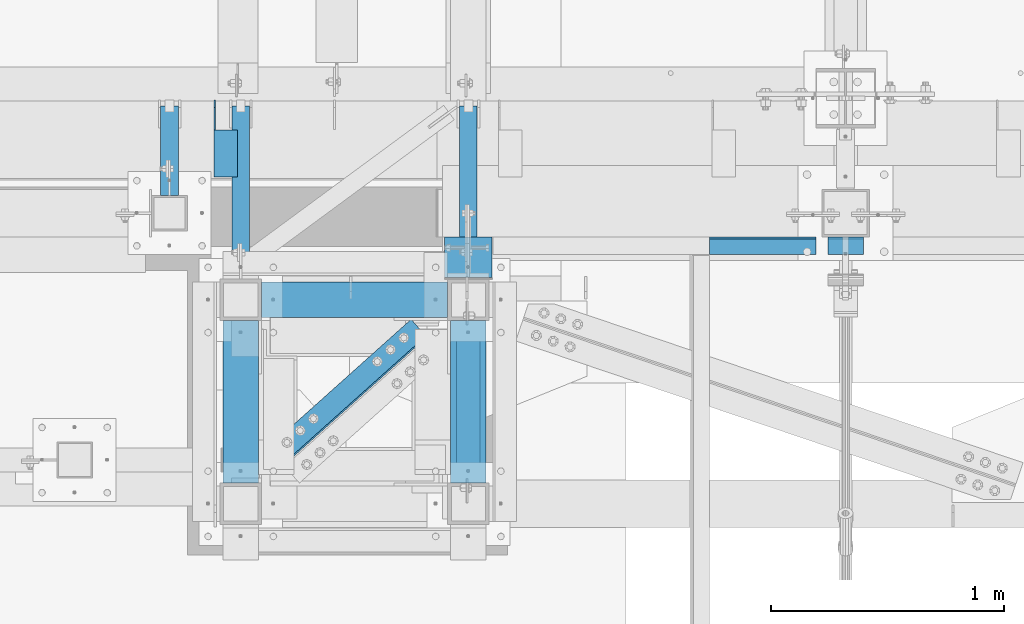
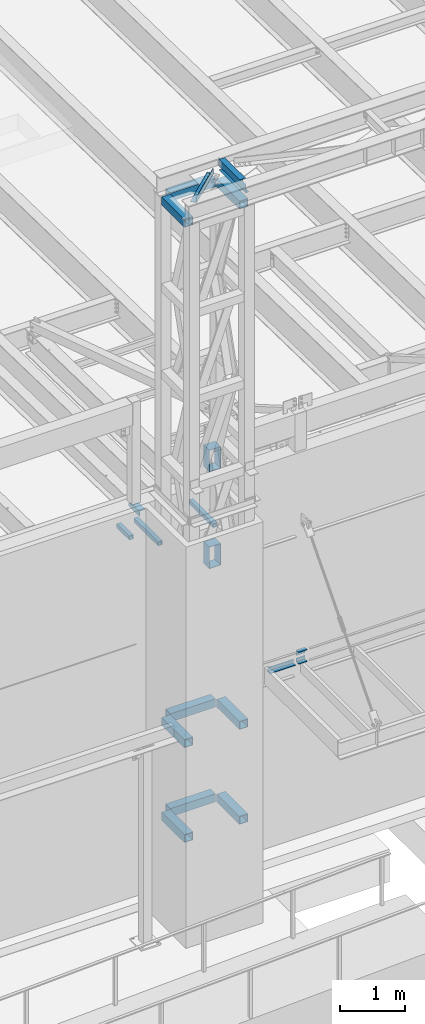
# One storey, part 1201 of 1763: 20 beams, 9 elements without a shape of their own.
"""IFC2X3 building model written with IfcOpenShell, lengths in millimetres."""

from ifc_helpers import new_model, si_unit, frame, origin_with_axes, place, context, subcontext, project, spatial, faceted_brep, material, type_object, element, aggregate, save


model = new_model("IFC2X3")

# Units and contexts
model_context = context("Model", 3, precision=1e-05, world=origin_with_axes())
body_context = subcontext(model_context, "Body", "Model", "MODEL_VIEW")
ifc_project = project(units=[si_unit("LENGTHUNIT", "METRE", prefix="MILLI"), si_unit("AREAUNIT", "SQUARE_METRE"), si_unit("VOLUMEUNIT", "CUBIC_METRE"), si_unit("MASSUNIT", "GRAM", prefix="KILO"), si_unit("TIMEUNIT", "SECOND"), si_unit("PLANEANGLEUNIT", "RADIAN"), si_unit("SOLIDANGLEUNIT", "STERADIAN"), si_unit("THERMODYNAMICTEMPERATUREUNIT", "DEGREE_CELSIUS"), si_unit("LUMINOUSINTENSITYUNIT", "LUMEN")], contexts=[model_context])

# Site, building, storey
site_placement = place(None, origin_with_axes())
site = spatial("IfcSite", under=ifc_project, at=site_placement, CompositionType="ELEMENT")
building_placement = place(site_placement, origin_with_axes())
building = spatial("IfcBuilding", under=site, at=building_placement, Name="Undefined", CompositionType="ELEMENT")
storey_placement = place(building_placement, origin_with_axes())
storey = spatial("IfcBuildingStorey", under=building, at=storey_placement, Name="Undefined", CompositionType="ELEMENT", Elevation=0.0)

# Assembly, beam
assembly_1_placement = place(storey_placement, origin_with_axes())
assembly_1 = element("IfcElementAssembly", 1, at=assembly_1_placement, inside=storey, Name="BEAM", AssemblyPlace="NOTDEFINED", PredefinedType="RIGID_FRAME")
ifc_material_1 = material(Name="STEEL/A36")
beam_type_1 = type_object("IfcBeamType", Name="L4X4X1/4", PredefinedType="NOTDEFINED")
beam_1_placement = place(assembly_1_placement, frame((-64249.6055562794, -13723.1435701431, 12153.9), z_axis=(0.0, 0.0, -1.0), x_axis=(0.0, -1.0, 0.0)))
beam_1 = element("IfcBeam", 2, at=beam_1_placement, type_object=beam_type_1, material=ifc_material_1, Name="BRACE", ObjectType="L4X4X1/4", context=body_context, shape_type="Brep", body=[
    faceted_brep([(127.793748474227, 44.4499999999971, -31.7500007627295), (127.793748474227, 50.8000000000029, -31.7500007627295), (127.793748474225, 50.8000000000029, -50.7999999999993), (127.793748474225, -50.8000000000029, -50.7999999999993), (127.793748474225, -50.8000000000029, -44.4500000000007), (127.793748474225, 44.4499999999971, -44.4500000000007), (31.7499999999673, 44.4499999999971, -31.7500001906901), (31.7499999999673, 50.8000000000029, -31.7500007627295), (-1.81898940354586e-10, 44.4500000000371, 50.7999999999374), (-1.96450855582952e-10, 50.8000000000393, 50.7999999999374), (0.0, 50.8000000000029, -1.90690116141923e-07), (0.0, 44.4499999999971, -1.90690116141923e-07), (329.406260681253, 44.4499999999971, 50.7999999999993), (329.406260681253, 50.8000000000029, 50.7999999999993), (329.406260681253, 44.4499999999971, -44.4500000000007), (329.406260681253, -50.8000000000029, -44.4500000000007), (329.406260681253, -50.8000000000029, -50.7999999999993), (329.406260681253, 50.8000000000029, -50.7999999999993)], [[[0, 1, 2, 3, 4, 5]], [[1, 0, 6, 7]], [[8, 9, 10, 11]], [[9, 8, 12, 13]], [[12, 14, 15, 16, 17, 13]], [[15, 14, 5, 4]], [[16, 15, 4, 3]], [[17, 16, 3, 2]], [[9, 13, 17, 2, 1, 7, 10]], [[6, 11, 10, 7]], [[0, 5, 14, 12, 8, 11, 6]]]),
])
aggregate(assembly_1, [beam_1])

assembly_2_placement = place(storey_placement, origin_with_axes())
assembly_2 = element("IfcElementAssembly", 3, at=assembly_2_placement, inside=storey, Name="ANGLE", AssemblyPlace="NOTDEFINED", PredefinedType="RIGID_FRAME")
beam_2_placement = place(assembly_2_placement, frame((-64219.1221853135, -15414.8880493635, 18672.175), z_axis=(-0.667212485940867, 0.744867436933988, 0.0), x_axis=(0.744867436933987, 0.667212485940868, 0.0)))
beam_2 = element("IfcBeam", 4, at=beam_2_placement, type_object=beam_type_1, material=ifc_material_1, Name="ANGLE", ObjectType="L4X4X1/4", context=body_context, shape_type="Brep", body=[
    faceted_brep([(246.665849237292, -50.7999999999993, -44.4499999995605), (246.665849237281, -50.7999999999993, -50.7999999995518), (1070.58066999025, -50.7999999999993, -50.7999999982494), (1070.58066999025, -50.7999999999993, -44.4499999982581), (246.665849237292, 44.4500000000007, -44.4499999995605), (1070.58066999025, 44.4500000000007, -44.4499999982581), (246.665849237394, 44.4500000000007, 50.8000000003231), (1070.58066999036, 44.4500000000007, 50.8000000016327), (246.665849237394, 50.7999999999993, 50.8000000003231), (1070.58066999036, 50.7999999999993, 50.8000000016327), (246.665849237281, 50.7999999999993, -50.7999999995518), (1070.58066999025, 50.7999999999993, -50.7999999982494)], [[[0, 1, 2, 3]], [[4, 0, 3, 5]], [[6, 4, 5, 7]], [[8, 6, 7, 9]], [[1, 0, 4, 6, 8, 10]], [[1, 10, 11, 2]], [[7, 5, 3, 2, 11, 9]], [[10, 8, 9, 11]]]),
])
aggregate(assembly_2, [beam_2])

assembly_3_placement = place(storey_placement, origin_with_axes())
assembly_3 = element("IfcElementAssembly", 5, at=assembly_3_placement, inside=storey, Name="BEAM", AssemblyPlace="NOTDEFINED", PredefinedType="RIGID_FRAME")
ifc_material_2 = material()
beam_type_2 = type_object("IfcBeamType", Name="HSS3X3X1/4", PredefinedType="NOTDEFINED")
beam_3_placement = place(assembly_3_placement, frame((-64490.482374092, -14131.9264769908, 11825.2875), z_axis=(0.0, 0.0, 1.0), x_axis=(0.0, 1.0, 0.0)))
beam_3 = element("IfcBeam", 6, at=beam_3_placement, type_object=beam_type_2, material=ifc_material_2, Name="BEAM", ObjectType="HSS3X3X1/4", context=body_context, shape_type="Brep", body=[
    faceted_brep([(0.0, 31.75, -31.75), (0.0, -31.75, -31.75), (383.382908373733, -31.75, -31.75), (383.382908373733, 31.75, -31.75), (0.0, -31.75, 31.75), (383.382908373733, -31.75, 31.75), (0.0, 31.75, 31.75), (383.382908373733, 31.75, 31.75), (0.0, 38.0999999999985, -38.1000000000004), (0.0, 38.0999999999985, 38.1000000000004), (383.382908373733, 38.0999999999985, 38.1000000000004), (383.382908373733, 38.0999999999985, -38.1000000000004), (0.0, -38.0999999999985, 38.1000000000004), (383.382908373733, -38.0999999999985, 38.1000000000004), (0.0, -38.0999999999985, -38.1000000000004), (383.382908373733, -38.0999999999985, -38.1000000000004)], [[[0, 1, 2, 3]], [[1, 4, 5, 2]], [[4, 6, 7, 5]], [[6, 0, 3, 7]], [[8, 9, 10, 11]], [[9, 12, 13, 10]], [[12, 14, 15, 13]], [[14, 8, 11, 15]], [[13, 15, 11, 10], [5, 7, 3, 2]], [[14, 12, 9, 8], [6, 4, 1, 0]]]),
])
aggregate(assembly_3, [beam_3])

assembly_4_placement = place(storey_placement, origin_with_axes())
assembly_4 = element("IfcElementAssembly", 7, at=assembly_4_placement, inside=storey, Name="BEAM", AssemblyPlace="NOTDEFINED", PredefinedType="RIGID_FRAME")
beam_4_placement = place(assembly_4_placement, frame((-63210.5025957005, -14490.7023151462, 11825.2875), z_axis=(0.0, 0.0, 1.0), x_axis=(0.0, 1.0, 0.0)))
beam_4 = element("IfcBeam", 8, at=beam_4_placement, type_object=beam_type_2, material=ifc_material_2, Name="BEAM", ObjectType="HSS3X3X1/4", context=body_context, shape_type="Brep", body=[
    faceted_brep([(0.0, 31.75, -31.75), (0.0, -31.75, -31.75), (742.15874652916, -31.75, -31.75), (742.15874652916, 31.75, -31.75), (0.0, -31.75, 31.75), (742.15874652916, -31.75, 31.75), (0.0, 31.75, 31.75), (742.15874652916, 31.75, 31.75), (0.0, 38.0999999999985, -38.1000000000004), (0.0, 38.0999999999985, 38.1000000000004), (742.15874652916, 38.0999999999985, 38.1000000000004), (742.15874652916, 38.0999999999985, -38.1000000000004), (0.0, -38.0999999999985, 38.1000000000004), (742.15874652916, -38.0999999999985, 38.1000000000004), (0.0, -38.0999999999985, -38.1000000000004), (742.15874652916, -38.0999999999985, -38.1000000000004)], [[[0, 1, 2, 3]], [[1, 4, 5, 2]], [[4, 6, 7, 5]], [[6, 0, 3, 7]], [[8, 9, 10, 11]], [[9, 12, 13, 10]], [[12, 14, 15, 13]], [[14, 8, 11, 15]], [[13, 15, 11, 10], [5, 7, 3, 2]], [[14, 12, 9, 8], [6, 4, 1, 0]]]),
])
aggregate(assembly_4, [beam_4])

assembly_5_placement = place(storey_placement, origin_with_axes())
assembly_5 = element("IfcElementAssembly", 9, at=assembly_5_placement, inside=storey, Name="BEAM", AssemblyPlace="NOTDEFINED", PredefinedType="RIGID_FRAME")
beam_5_placement = place(assembly_5_placement, frame((-64185.2277910131, -14490.7023151462, 11825.2875), z_axis=(0.0, 0.0, 1.0), x_axis=(0.0, 1.0, 0.0)))
beam_5 = element("IfcBeam", 10, at=beam_5_placement, type_object=beam_type_2, material=ifc_material_2, Name="BEAM", ObjectType="HSS3X3X1/4", context=body_context, shape_type="Brep", body=[
    faceted_brep([(0.0, 31.75, -31.75), (0.0, -31.75, -31.75), (742.15874652916, -31.75, -31.75), (742.15874652916, 31.75, -31.75), (0.0, -31.75, 31.75), (742.15874652916, -31.75, 31.75), (0.0, 31.75, 31.75), (742.15874652916, 31.75, 31.75), (0.0, 38.0999999999985, -38.1000000000004), (0.0, 38.0999999999985, 38.1000000000004), (742.15874652916, 38.0999999999985, 38.1000000000004), (742.15874652916, 38.0999999999985, -38.1000000000004), (0.0, -38.0999999999985, 38.1000000000004), (742.15874652916, -38.0999999999985, 38.1000000000004), (0.0, -38.0999999999985, -38.1000000000004), (742.15874652916, -38.0999999999985, -38.1000000000004)], [[[0, 1, 2, 3]], [[1, 4, 5, 2]], [[4, 6, 7, 5]], [[6, 0, 3, 7]], [[8, 9, 10, 11]], [[9, 12, 13, 10]], [[12, 14, 15, 13]], [[14, 8, 11, 15]], [[13, 15, 11, 10], [5, 7, 3, 2]], [[14, 12, 9, 8], [6, 4, 1, 0]]]),
])
aggregate(assembly_5, [beam_5])

# Assembly, beams
assembly_6_placement = place(storey_placement, origin_with_axes())
assembly_6 = element("IfcElementAssembly", 11, at=assembly_6_placement, inside=storey, Name="FRAME", AssemblyPlace="NOTDEFINED", PredefinedType="RIGID_FRAME")
beam_type_3 = type_object("IfcBeamType", Name="HSS6X6X3/8", PredefinedType="NOTDEFINED")
beam_6_placement = place(assembly_6_placement, frame((-64185.2275957006, -14579.6023151462, 18373.725), z_axis=(0.0, 0.0, 1.0), x_axis=(0.99999999999718, 2.37500000002911e-06, 0.0)))
beam_6 = element("IfcBeam", 12, at=beam_6_placement, type_object=beam_type_3, material=ifc_material_2, Name="BEAM", ObjectType="HSS6X6X3/8", context=body_context, shape_type="Brep", body=[
    faceted_brep([(88.8999999999996, 66.6750000000029, -66.6749999999993), (88.8996463353687, -66.6749999999556, -66.6749999999993), (885.824841654605, -66.6750000000393, -66.6749999999993), (885.825158360378, 66.6749999998519, -66.6749999999993), (88.8996463353687, -66.6749999999556, 66.6749999999993), (885.824841654605, -66.6750000000393, 66.6749999999993), (88.8999999999996, 66.6750000000029, 66.6749999999993), (885.825158360378, 66.6749999998519, 66.6749999999993), (88.8999999999996, 76.1999999999971, -76.2000000000007), (88.8999999999996, 76.1999999999971, 76.2000000000007), (885.825180982218, 76.1999999998425, 76.2000000000007), (885.825180982218, 76.1999999998425, -76.2000000000007), (88.8996237135289, -76.1999999999498, 76.2000000000007), (885.824819032772, -76.2000000000335, 76.2000000000007), (88.8996237135289, -76.1999999999498, -76.2000000000007), (885.824819032772, -76.2000000000335, -76.2000000000007)], [[[0, 1, 2, 3]], [[1, 4, 5, 2]], [[4, 6, 7, 5]], [[6, 0, 3, 7]], [[8, 9, 10, 11]], [[9, 12, 13, 10]], [[12, 14, 15, 13]], [[14, 8, 11, 15]], [[13, 15, 11, 10], [5, 7, 3, 2]], [[14, 12, 9, 8], [6, 4, 1, 0]]]),
])
beam_7_placement = place(assembly_6_placement, frame((-63210.5025951483, -15452.7272159449, 18373.725), z_axis=(0.0, 0.0, 1.0), x_axis=(0.0, 1.0, 0.0)))
beam_7 = element("IfcBeam", 13, at=beam_7_placement, type_object=beam_type_3, material=ifc_material_2, Name="BEAM", ObjectType="HSS6X6X3/8", context=body_context, shape_type="Brep", body=[
    faceted_brep([(88.8999008650717, 66.6749999997191, -66.6749999999993), (88.8999007322054, -66.6750000002794, -66.6749999999993), (784.224900732206, -66.6750000025058, -66.6749999999993), (784.224900865072, 66.6749999974927, -66.6749999999993), (88.8999007322054, -66.6750000002794, 66.6749999999993), (784.224900732206, -66.6750000025058, 66.6749999999993), (88.8999008650717, 66.6749999997191, 66.6749999999993), (784.224900865072, 66.6749999974927, 66.6749999999993), (88.8999008745614, 76.1999999997206, -76.2000000000007), (88.8999008745614, 76.1999999997206, 76.2000000000007), (784.224900874562, 76.1999999974942, 76.2000000000007), (784.224900874562, 76.1999999974942, -76.2000000000007), (88.8999007227158, -76.2000000002809, 76.2000000000007), (784.224900722716, -76.2000000025073, 76.2000000000007), (88.8999007227158, -76.2000000002809, -76.2000000000007), (784.224900722716, -76.2000000025073, -76.2000000000007)], [[[0, 1, 2, 3]], [[1, 4, 5, 2]], [[4, 6, 7, 5]], [[6, 0, 3, 7]], [[8, 9, 10, 11]], [[9, 12, 13, 10]], [[12, 14, 15, 13]], [[14, 8, 11, 15]], [[13, 15, 11, 10], [5, 7, 3, 2]], [[14, 12, 9, 8], [6, 4, 1, 0]]]),
])
beam_8_placement = place(assembly_6_placement, frame((-64185.2275951483, -15452.7272100983, 18373.725), z_axis=(0.0, 0.0, 1.0), x_axis=(0.0, 1.0, 0.0)))
beam_8 = element("IfcBeam", 14, at=beam_8_placement, type_object=beam_type_3, material=ifc_material_2, Name="BEAM", ObjectType="HSS6X6X3/8", context=body_context, shape_type="Brep", body=[
    faceted_brep([(88.8999008650717, 66.6749999997191, -66.6749999999993), (88.8999007322054, -66.6750000002794, -66.6749999999993), (784.224900732206, -66.6750000025058, -66.6749999999993), (784.224900865072, 66.6749999974927, -66.6749999999993), (88.8999007322054, -66.6750000002794, 66.6749999999993), (784.224900732206, -66.6750000025058, 66.6749999999993), (88.8999008650717, 66.6749999997191, 66.6749999999993), (784.224900865072, 66.6749999974927, 66.6749999999993), (88.8999008745614, 76.1999999997206, -76.2000000000007), (88.8999008745614, 76.1999999997206, 76.2000000000007), (784.224900874562, 76.1999999974942, 76.2000000000007), (784.224900874562, 76.1999999974942, -76.2000000000007), (88.8999007227158, -76.2000000002809, 76.2000000000007), (784.224900722716, -76.2000000025073, 76.2000000000007), (88.8999007227158, -76.2000000002809, -76.2000000000007), (784.224900722716, -76.2000000025073, -76.2000000000007)], [[[0, 1, 2, 3]], [[1, 4, 5, 2]], [[4, 6, 7, 5]], [[6, 0, 3, 7]], [[8, 9, 10, 11]], [[9, 12, 13, 10]], [[12, 14, 15, 13]], [[14, 8, 11, 15]], [[13, 15, 11, 10], [5, 7, 3, 2]], [[14, 12, 9, 8], [6, 4, 1, 0]]]),
])
beam_9_placement = place(assembly_6_placement, frame((-64185.2275957006, -14579.6023151462, 8623.3), z_axis=(0.0, 0.0, 1.0), x_axis=(0.99999999999718, 2.37500000002911e-06, 0.0)))
beam_9 = element("IfcBeam", 15, at=beam_9_placement, type_object=beam_type_3, material=ifc_material_2, Name="BEAM", ObjectType="HSS6X6X3/8", context=body_context, shape_type="Brep", body=[
    faceted_brep([(88.8999999999996, 66.6750000000029, -66.6749999999993), (88.8996463353687, -66.6749999999556, -66.6749999999993), (885.824841654605, -66.6750000000393, -66.6749999999993), (885.825158360378, 66.6749999998519, -66.6749999999993), (88.8996463353687, -66.6749999999556, 66.6749999999993), (885.824841654605, -66.6750000000393, 66.6749999999993), (88.8999999999996, 66.6750000000029, 66.6749999999993), (885.825158360378, 66.6749999998519, 66.6749999999993), (88.8999999999996, 76.1999999999971, -76.2000000000007), (88.8999999999996, 76.1999999999971, 76.2000000000007), (885.825180982218, 76.1999999998425, 76.2000000000007), (885.825180982218, 76.1999999998425, -76.2000000000007), (88.8996237135289, -76.1999999999498, 76.2000000000007), (885.824819032772, -76.2000000000335, 76.2000000000007), (88.8996237135289, -76.1999999999498, -76.2000000000007), (885.824819032772, -76.2000000000335, -76.2000000000007)], [[[0, 1, 2, 3]], [[1, 4, 5, 2]], [[4, 6, 7, 5]], [[6, 0, 3, 7]], [[8, 9, 10, 11]], [[9, 12, 13, 10]], [[12, 14, 15, 13]], [[14, 8, 11, 15]], [[13, 15, 11, 10], [5, 7, 3, 2]], [[14, 12, 9, 8], [6, 4, 1, 0]]]),
])
beam_10_placement = place(assembly_6_placement, frame((-63210.5025957005, -15452.7273151462, 8623.3), z_axis=(0.0, 0.0, 1.0), x_axis=(0.0, 1.0, 0.0)))
beam_10 = element("IfcBeam", 16, at=beam_10_placement, type_object=beam_type_3, material=ifc_material_2, Name="BEAM", ObjectType="HSS6X6X3/8", context=body_context, shape_type="Brep", body=[
    faceted_brep([(88.8999999999996, 66.6750000000029, -66.6749999999993), (88.8999999999996, -66.6750000000029, -66.6749999999993), (784.225, -66.6750000000029, -66.6749999999993), (784.225, 66.6750000000029, -66.6749999999993), (88.8999999999996, -66.6750000000029, 66.6749999999993), (784.225, -66.6750000000029, 66.6749999999993), (88.8999999999996, 66.6750000000029, 66.6749999999993), (784.225, 66.6750000000029, 66.6749999999993), (88.8999999999996, 76.1999999999971, -76.2000000000007), (88.8999999999996, 76.1999999999971, 76.2000000000007), (784.225, 76.1999999999971, 76.2000000000007), (784.225, 76.1999999999971, -76.2000000000007), (88.8999999999996, -76.1999999999971, 76.2000000000007), (784.225, -76.1999999999971, 76.2000000000007), (88.8999999999996, -76.1999999999971, -76.2000000000007), (784.225, -76.1999999999971, -76.2000000000007)], [[[0, 1, 2, 3]], [[1, 4, 5, 2]], [[4, 6, 7, 5]], [[6, 0, 3, 7]], [[8, 9, 10, 11]], [[9, 12, 13, 10]], [[12, 14, 15, 13]], [[14, 8, 11, 15]], [[13, 15, 11, 10], [5, 7, 3, 2]], [[14, 12, 9, 8], [6, 4, 1, 0]]]),
])
beam_11_placement = place(assembly_6_placement, frame((-64185.2275957006, -15452.7273151462, 8623.3), z_axis=(0.0, 0.0, 1.0), x_axis=(0.0, 1.0, 0.0)))
beam_11 = element("IfcBeam", 17, at=beam_11_placement, type_object=beam_type_3, material=ifc_material_2, Name="BEAM", ObjectType="HSS6X6X3/8", context=body_context, shape_type="Brep", body=[
    faceted_brep([(88.8999999999996, 66.6750000000029, -66.6749999999993), (88.8999999999996, -66.6750000000029, -66.6749999999993), (784.225, -66.6750000000029, -66.6749999999993), (784.225, 66.6750000000029, -66.6749999999993), (88.8999999999996, -66.6750000000029, 66.6749999999993), (784.225, -66.6750000000029, 66.6749999999993), (88.8999999999996, 66.6750000000029, 66.6749999999993), (784.225, 66.6750000000029, 66.6749999999993), (88.8999999999996, 76.1999999999971, -76.2000000000007), (88.8999999999996, 76.1999999999971, 76.2000000000007), (784.225, 76.1999999999971, 76.2000000000007), (784.225, 76.1999999999971, -76.2000000000007), (88.8999999999996, -76.1999999999971, 76.2000000000007), (784.225, -76.1999999999971, 76.2000000000007), (88.8999999999996, -76.1999999999971, -76.2000000000007), (784.225, -76.1999999999971, -76.2000000000007)], [[[0, 1, 2, 3]], [[1, 4, 5, 2]], [[4, 6, 7, 5]], [[6, 0, 3, 7]], [[8, 9, 10, 11]], [[9, 12, 13, 10]], [[12, 14, 15, 13]], [[14, 8, 11, 15]], [[13, 15, 11, 10], [5, 7, 3, 2]], [[14, 12, 9, 8], [6, 4, 1, 0]]]),
])
beam_12_placement = place(assembly_6_placement, frame((-64185.2275957006, -14579.6023151462, 6845.3), z_axis=(0.0, 0.0, 1.0), x_axis=(0.99999999999718, 2.37500000002911e-06, 0.0)))
beam_12 = element("IfcBeam", 18, at=beam_12_placement, type_object=beam_type_3, material=ifc_material_2, Name="BEAM", ObjectType="HSS6X6X3/8", context=body_context, shape_type="Brep", body=[
    faceted_brep([(88.8999999999996, 66.6750000000029, -66.6749999999993), (88.8996463353687, -66.6749999999556, -66.6749999999993), (885.824841654605, -66.6750000000393, -66.6749999999993), (885.825158360378, 66.6749999998519, -66.6749999999993), (88.8996463353687, -66.6749999999556, 66.6749999999993), (885.824841654605, -66.6750000000393, 66.6749999999993), (88.8999999999996, 66.6750000000029, 66.6749999999993), (885.825158360378, 66.6749999998519, 66.6749999999993), (88.8999999999996, 76.1999999999971, -76.2000000000007), (88.8999999999996, 76.1999999999971, 76.2000000000007), (885.825180982218, 76.1999999998425, 76.2000000000007), (885.825180982218, 76.1999999998425, -76.2000000000007), (88.8996237135289, -76.1999999999498, 76.2000000000007), (885.824819032772, -76.2000000000335, 76.2000000000007), (88.8996237135289, -76.1999999999498, -76.2000000000007), (885.824819032772, -76.2000000000335, -76.2000000000007)], [[[0, 1, 2, 3]], [[1, 4, 5, 2]], [[4, 6, 7, 5]], [[6, 0, 3, 7]], [[8, 9, 10, 11]], [[9, 12, 13, 10]], [[12, 14, 15, 13]], [[14, 8, 11, 15]], [[13, 15, 11, 10], [5, 7, 3, 2]], [[14, 12, 9, 8], [6, 4, 1, 0]]]),
])
beam_13_placement = place(assembly_6_placement, frame((-63210.5025957005, -15452.7273151462, 6845.3), z_axis=(0.0, 0.0, 1.0), x_axis=(0.0, 1.0, 0.0)))
beam_13 = element("IfcBeam", 19, at=beam_13_placement, type_object=beam_type_3, material=ifc_material_2, Name="BEAM", ObjectType="HSS6X6X3/8", context=body_context, shape_type="Brep", body=[
    faceted_brep([(88.8999999999996, 66.6750000000029, -66.6749999999993), (88.8999999999996, -66.6750000000029, -66.6749999999993), (784.225, -66.6750000000029, -66.6749999999993), (784.225, 66.6750000000029, -66.6749999999993), (88.8999999999996, -66.6750000000029, 66.6749999999993), (784.225, -66.6750000000029, 66.6749999999993), (88.8999999999996, 66.6750000000029, 66.6749999999993), (784.225, 66.6750000000029, 66.6749999999993), (88.8999999999996, 76.1999999999971, -76.2000000000007), (88.8999999999996, 76.1999999999971, 76.2000000000007), (784.225, 76.1999999999971, 76.2000000000007), (784.225, 76.1999999999971, -76.2000000000007), (88.8999999999996, -76.1999999999971, 76.2000000000007), (784.225, -76.1999999999971, 76.2000000000007), (88.8999999999996, -76.1999999999971, -76.2000000000007), (784.225, -76.1999999999971, -76.2000000000007)], [[[0, 1, 2, 3]], [[1, 4, 5, 2]], [[4, 6, 7, 5]], [[6, 0, 3, 7]], [[8, 9, 10, 11]], [[9, 12, 13, 10]], [[12, 14, 15, 13]], [[14, 8, 11, 15]], [[13, 15, 11, 10], [5, 7, 3, 2]], [[14, 12, 9, 8], [6, 4, 1, 0]]]),
])
beam_14_placement = place(assembly_6_placement, frame((-64185.2275957006, -15452.7273151462, 6845.3), z_axis=(0.0, 0.0, 1.0), x_axis=(0.0, 1.0, 0.0)))
beam_14 = element("IfcBeam", 20, at=beam_14_placement, type_object=beam_type_3, material=ifc_material_2, Name="BEAM", ObjectType="HSS6X6X3/8", context=body_context, shape_type="Brep", body=[
    faceted_brep([(88.8999999999996, 66.6750000000029, -66.6749999999993), (88.8999999999996, -66.6750000000029, -66.6749999999993), (784.225, -66.6750000000029, -66.6749999999993), (784.225, 66.6750000000029, -66.6749999999993), (88.8999999999996, -66.6750000000029, 66.6749999999993), (784.225, -66.6750000000029, 66.6749999999993), (88.8999999999996, 66.6750000000029, 66.6749999999993), (784.225, 66.6750000000029, 66.6749999999993), (88.8999999999996, 76.1999999999971, -76.2000000000007), (88.8999999999996, 76.1999999999971, 76.2000000000007), (784.225, 76.1999999999971, 76.2000000000007), (784.225, 76.1999999999971, -76.2000000000007), (88.8999999999996, -76.1999999999971, 76.2000000000007), (784.225, -76.1999999999971, 76.2000000000007), (88.8999999999996, -76.1999999999971, -76.2000000000007), (784.225, -76.1999999999971, -76.2000000000007)], [[[0, 1, 2, 3]], [[1, 4, 5, 2]], [[4, 6, 7, 5]], [[6, 0, 3, 7]], [[8, 9, 10, 11]], [[9, 12, 13, 10]], [[12, 14, 15, 13]], [[14, 8, 11, 15]], [[13, 15, 11, 10], [5, 7, 3, 2]], [[14, 12, 9, 8], [6, 4, 1, 0]]]),
])
beam_type_4 = type_object("IfcBeamType", Name="HSS16X8X1/4", PredefinedType="NOTDEFINED")
beam_15_placement = place(assembly_6_placement, frame((-63210.5025999486, -14490.702315147, 13055.6221257957), z_axis=(0.0, 0.0, 1.0), x_axis=(0.0, 1.0, 0.0)))
beam_15 = element("IfcBeam", 21, at=beam_15_placement, type_object=beam_type_4, material=ifc_material_2, Name="BEAM", ObjectType="HSS16X8X1/4", context=body_context, shape_type="Brep", body=[
    faceted_brep([(6.35000009548457, 95.2499999999854, -196.85), (6.3499999048563, -95.2500000000146, -196.85), (180.974693656795, -95.2500000003201, -196.85), (180.97469365679, 95.2499999996799, -196.85), (6.3499999048563, -95.2500000000146, 196.85), (180.974693656795, -95.2500000003201, 196.85), (6.35000009548457, 95.2499999999854, 196.85), (180.97469365679, 95.2499999996799, 196.85), (6.35000010184012, 101.599999999984, -203.200000000001), (6.35000010184012, 101.599999999984, 203.200000000001), (180.974693656788, 101.599999999678, 203.200000000001), (180.974693656788, 101.599999999678, -203.200000000001), (6.34999989850257, -101.600000000013, 203.200000000001), (180.974693656795, -101.600000000326, 203.200000000001), (6.34999989850257, -101.600000000013, -203.200000000001), (180.974693656795, -101.600000000326, -203.200000000001)], [[[0, 1, 2, 3]], [[1, 4, 5, 2]], [[4, 6, 7, 5]], [[6, 0, 3, 7]], [[8, 9, 10, 11]], [[9, 12, 13, 10]], [[12, 14, 15, 13]], [[14, 8, 11, 15]], [[13, 15, 11, 10], [5, 7, 3, 2]], [[14, 12, 9, 8], [6, 4, 1, 0]]]),
])
beam_16_placement = place(assembly_6_placement, frame((-63210.5025957006, -14490.7023090427, 11239.5), z_axis=(0.0, 0.0, 1.0), x_axis=(0.0, 1.0, 0.0)))
beam_16 = element("IfcBeam", 22, at=beam_16_placement, type_object=beam_type_4, material=ifc_material_2, Name="BEAM", ObjectType="HSS16X8X1/4", context=body_context, shape_type="Brep", body=[
    faceted_brep([(6.35000009548457, 95.2499999999854, -196.85), (6.3499999048563, -95.2500000000146, -196.85), (180.974693656795, -95.2500000003201, -196.85), (180.97469365679, 95.2499999996799, -196.85), (6.3499999048563, -95.2500000000146, 196.85), (180.974693656795, -95.2500000003201, 196.85), (6.35000009548457, 95.2499999999854, 196.85), (180.97469365679, 95.2499999996799, 196.85), (6.35000010184012, 101.599999999984, -203.200000000001), (6.35000010184012, 101.599999999984, 203.200000000001), (180.974693656788, 101.599999999678, 203.200000000001), (180.974693656788, 101.599999999678, -203.200000000001), (6.34999989850257, -101.600000000013, 203.200000000001), (180.974693656795, -101.600000000326, 203.200000000001), (6.34999989850257, -101.600000000013, -203.200000000001), (180.974693656795, -101.600000000326, -203.200000000001)], [[[0, 1, 2, 3]], [[1, 4, 5, 2]], [[4, 6, 7, 5]], [[6, 0, 3, 7]], [[8, 9, 10, 11]], [[9, 12, 13, 10]], [[12, 14, 15, 13]], [[14, 8, 11, 15]], [[13, 15, 11, 10], [5, 7, 3, 2]], [[14, 12, 9, 8], [6, 4, 1, 0]]]),
])
aggregate(assembly_6, [beam_6, beam_7, beam_8, beam_9, beam_10, beam_11, beam_12, beam_13, beam_14, beam_15, beam_16])

# Assembly, beam
assembly_7_placement = place(storey_placement, origin_with_axes())
assembly_7 = element("IfcElementAssembly", 23, at=assembly_7_placement, inside=storey, Name="BEAM", AssemblyPlace="NOTDEFINED", PredefinedType="RIGID_FRAME")
ifc_material_3 = material(Name="STEEL/A992")
beam_type_5 = type_object("IfcBeamType", Name="W8X10", PredefinedType="NOTDEFINED")
beam_17_placement = place(assembly_7_placement, frame((-63210.5025957005, -15452.7272158686, 18721.3875), z_axis=(0.0, 0.0, 1.0), x_axis=(0.0, 1.0, 0.0)))
beam_17 = element("IfcBeam", 24, at=beam_17_placement, type_object=beam_type_5, material=ifc_material_3, Name="BEAM", ObjectType="W8X10", context=body_context, shape_type="Brep", body=[
    faceted_brep([(754.062393478449, 2.68138280149287, -95.25), (754.062393478942, 2.68111437270272, -100.012500000001), (754.062304651585, 50.8000000000029, -100.012500000001), (754.062304651585, 50.8000000000029, -95.25), (855.662499936947, 2.68157035501645, -95.25), (855.662499936945, 2.68130192623357, -100.012500000001), (119.062499920861, 2.38124999999854, 95.25), (119.062548753725, 50.7999999995227, 95.25), (754.062499920858, 50.8000000000029, 95.25), (754.062499920858, 2.38124999999854, 95.25), (119.062499920861, -50.8000000000029, 100.012500000001), (119.062548753725, 50.7999999995227, 100.012500000001), (119.062499920861, 2.38124999999854, 74.3525014877341), (119.062499920861, -2.38124999999854, 74.3525014877341), (119.062499920861, -2.38124999999854, 95.25), (119.062499920861, -50.8000000000029, 95.25), (118.095769998274, 2.38124999999854, 69.4924219696877), (118.095769998274, -2.38124999999854, 69.4924219696877), (115.342756097796, 2.38124999999854, 65.3722455015341), (115.342756097796, -2.38124999999854, 65.3722455015341), (111.222579629642, 2.38124999999854, 62.6192316010565), (111.222579629642, -2.38124999999854, 62.6192316010565), (106.362500111596, 2.38124999999854, 61.652501678469), (106.362500111596, -2.38124999999854, 61.652501678469), (17.462499935149, 2.38124999999854, 61.652501678469), (17.4624999065727, -2.38124999999854, 61.652501678469), (119.062558086149, 50.7999999995154, -95.25), (119.062558086149, 50.7999999995154, -100.012500000001), (119.062597975411, 2.68138261623972, -100.012500000001), (119.062597975906, 2.68111418744229, -95.25), (17.462499936948, 2.68119506251242, -100.012500000001), (17.4624999369462, 2.68092663372954, -95.25), (17.4624996160601, -50.8000000000029, -100.012500000001), (17.4624996160601, -50.8000000000029, -95.25), (17.4624999065727, -2.38124999999854, -95.25), (17.462499935149, 2.38124999999854, -95.25), (855.662499616057, -50.8000000000029, -100.012500000001), (855.662499616057, -50.8000000000029, -95.25), (855.66249990657, -2.38124999999854, -95.25), (761.902420212076, -2.38124999999854, 62.6192316010565), (757.782243743923, -2.38124999999854, 65.3722455015341), (755.029229843445, -2.38124999999854, 69.4924219696877), (754.062499920858, -2.38124999999854, 74.3525014877341), (754.062499920858, -2.38124999999854, 95.25), (855.66249990657, -2.38124999999854, 61.652501678469), (766.762499730123, -2.38124999999854, 61.652501678469), (754.062499920858, -50.8000000000029, 95.25), (754.062499920858, -50.8000000000029, 100.012500000001), (754.062499920858, 50.8000000000029, 100.012500000001), (754.062499920858, 2.38124999999854, 74.3525014877341), (755.029229843445, 2.38124999999854, 69.4924219696877), (757.782243743923, 2.38124999999854, 65.3722455015341), (761.902420212076, 2.38124999999854, 62.6192316010565), (766.762499730123, 2.38124999999854, 61.652501678469), (855.662499935146, 2.38124999999854, 61.652501678469), (855.662499935146, 2.38124999999854, -95.25)], [[[0, 1, 2, 3]], [[4, 5, 1, 0]], [[6, 7, 8, 9]], [[10, 11, 7, 6, 12, 13, 14, 15]], [[13, 12, 16, 17]], [[17, 16, 18, 19]], [[19, 18, 20, 21]], [[21, 20, 22, 23]], [[23, 22, 24, 25]], [[26, 27, 28, 29]], [[29, 28, 30, 31]], [[32, 33, 34, 25, 24, 35, 31, 30]], [[33, 32, 36, 37]], [[34, 33, 37, 38]], [[39, 40, 41, 42, 43, 14, 13, 17, 19, 21, 23, 25, 34, 38, 44, 45]], [[15, 14, 43, 46]], [[10, 15, 46, 47]], [[11, 10, 47, 48]], [[7, 11, 48, 8]], [[47, 46, 43, 42, 49, 9, 8, 48]], [[41, 50, 49, 42]], [[40, 51, 50, 41]], [[39, 52, 51, 40]], [[45, 53, 52, 39]], [[44, 54, 53, 45]], [[55, 35, 24, 22, 20, 18, 16, 12, 6, 9, 49, 50, 51, 52, 53, 54]], [[3, 26, 29, 31, 35, 55, 4, 0]], [[27, 26, 3, 2]], [[36, 32, 30, 28, 27, 2, 1, 5]], [[55, 54, 44, 38, 37, 36, 5, 4]]]),
])
aggregate(assembly_7, [beam_17])

assembly_8_placement = place(storey_placement, origin_with_axes())
assembly_8 = element("IfcElementAssembly", 25, at=assembly_8_placement, inside=storey, Name="COLUMN", AssemblyPlace="NOTDEFINED", PredefinedType="RIGID_FRAME")
beam_type_6 = type_object("IfcBeamType", Name="L3X3X3/8", PredefinedType="NOTDEFINED")
beam_18_placement = place(assembly_8_placement, frame((-61518.2270160026, -14347.8276478541, 8648.70000000001), z_axis=(0.0, -1.0, 0.0), x_axis=(-1.0, 0.0, 0.0)))
beam_18 = element("IfcBeam", 26, at=beam_18_placement, type_object=beam_type_6, material=ifc_material_1, Name="ANGLE", ObjectType="L3X3X3/8", context=body_context, shape_type="Brep", body=[
    faceted_brep([(0.0, 38.0999999999985, -38.1000000000004), (0.0, 38.0999999999985, 38.1000000000004), (152.400006103515, 38.0999999999985, 38.1000000000058), (152.400006103515, 38.0999999999985, -38.1000000000058), (1.45519152283669e-11, 28.5750000000007, 38.1000000000022), (152.400000000023, 28.5750000000007, 38.0999999999622), (0.0, 28.5750000000007, -28.5750000000007), (152.400000000009, 28.5750000000007, -28.5750000000389), (0.0, -38.1000000000004, -28.5750000000007), (152.400000000009, -38.1000000000004, -28.5750000000389), (0.0, -38.0999999999985, -38.1000000000004), (152.400006103515, -38.0999999999985, -38.1000000000058)], [[[0, 1, 2, 3]], [[1, 4, 5, 2]], [[4, 6, 7, 5]], [[6, 8, 9, 7]], [[8, 10, 11, 9]], [[10, 0, 3, 11]], [[5, 7, 9, 11, 3, 2]], [[10, 8, 6, 4, 1, 0]]]),
])

assembly_9_placement = place(storey_placement, origin_with_axes())
assembly_9 = element("IfcElementAssembly", 27, at=assembly_9_placement, inside=storey, Name="BEAM", AssemblyPlace="NOTDEFINED", PredefinedType="RIGID_FRAME")
beam_19_placement = place(assembly_9_placement, frame((-61721.4269585856, -14347.8268314617, 8648.7), z_axis=(1.73499999800697e-06, -0.999999999998495, 0.0), x_axis=(-0.999999999998495, -1.73499999994274e-06, 0.0)))
beam_19 = element("IfcBeam", 28, at=beam_19_placement, type_object=beam_type_6, material=ifc_material_1, Name="ANGLE", ObjectType="L3X3X3/8", context=body_context, shape_type="Brep", body=[
    faceted_brep([(0.0, 38.0999999999985, -38.1000000000004), (0.0, 38.0999999999985, 38.1000000000004), (455.414045640158, 38.1000000000004, 38.0999999997075), (455.414045640391, 38.1000000000004, -38.1000000002678), (1.45519152283669e-11, 28.5750000000007, 38.1000000000022), (455.414045640158, 28.5750000000007, 38.0999999997075), (0.0, 28.5750000000007, -28.5750000000007), (455.414045640362, 28.5750000000007, -28.5750000002736), (0.0, -38.1000000000004, -28.5750000000007), (455.414045640362, -38.1000000000004, -28.5750000002736), (0.0, -38.0999999999985, -38.1000000000004), (455.414045640391, -38.1000000000004, -38.1000000002678)], [[[0, 1, 2, 3]], [[1, 4, 5, 2]], [[4, 6, 7, 5]], [[6, 8, 9, 7]], [[8, 10, 11, 9]], [[10, 0, 3, 11]], [[5, 7, 9, 11, 3, 2]], [[10, 8, 6, 4, 1, 0]]]),
])
aggregate(assembly_9, [beam_19])

# Beam
beam_type_7 = type_object("IfcBeamType", Name="L4X3X3/8", PredefinedType="NOTDEFINED")
beam_20_placement = place(assembly_8_placement, frame((-61518.2270131855, -14347.8276396054, 8788.4), z_axis=(0.0, 0.0, -1.0), x_axis=(-1.0, 0.0, 0.0)))
beam_20 = element("IfcBeam", 29, at=beam_20_placement, type_object=beam_type_7, material=ifc_material_1, Name="ANGLE", ObjectType="L4X3X3/8", context=body_context, shape_type="Brep", body=[
    faceted_brep([(1.45519152283669e-10, 38.0999999999985, -50.7999999999993), (1.45519152283669e-10, 38.0999999999985, 50.7999999999993), (152.400000000147, 38.1000000000186, 50.7999999999993), (152.400000000147, 38.1000000000186, -50.7999999999993), (1.09139364212751e-10, 28.5749999999989, 50.7999999999993), (152.400000000111, 28.5750000000171, 50.7999999999993), (1.09139364212751e-10, 28.5749999999989, -41.2749999999996), (152.400000000111, 28.5750000000171, -41.2749999999996), (-1.23691279441118e-10, -38.1000000000022, -41.2749999999996), (152.399999999878, -38.0999999999822, -41.2749999999996), (-1.23691279441118e-10, -38.1000000000022, -50.7999999999993), (152.399999999878, -38.0999999999822, -50.7999999999993)], [[[0, 1, 2, 3]], [[1, 4, 5, 2]], [[4, 6, 7, 5]], [[6, 8, 9, 7]], [[8, 10, 11, 9]], [[10, 0, 3, 11]], [[5, 7, 9, 11, 3, 2]], [[10, 8, 6, 4, 1, 0]]]),
])

aggregate(assembly_8, [beam_18, beam_20])

save(model, "model.ifc")
